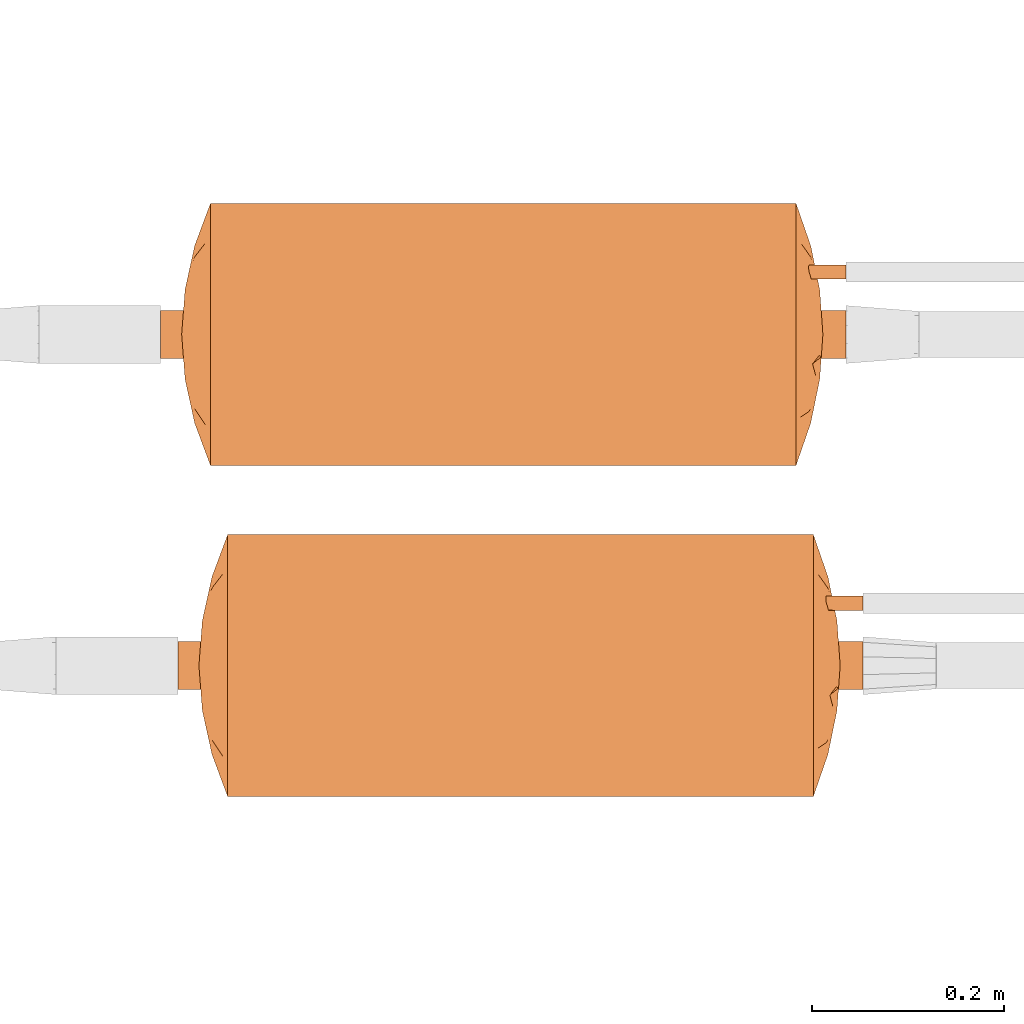
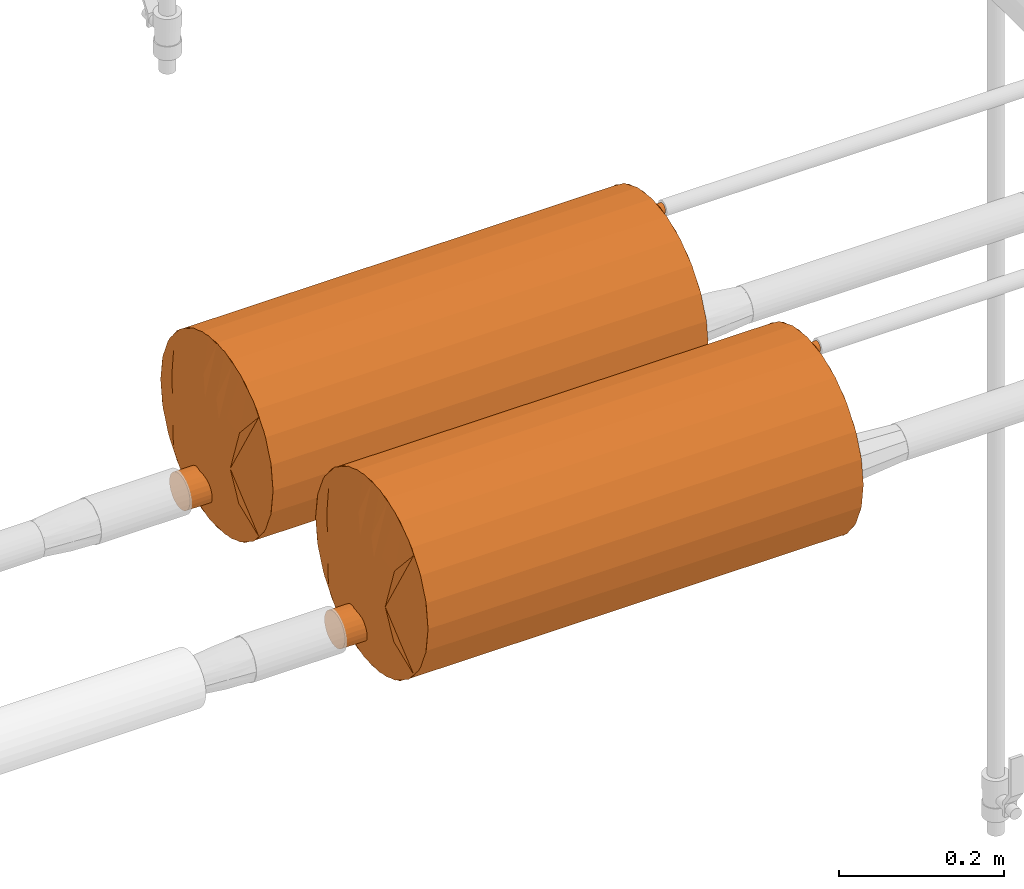
# One storey, part 825 of 827: 2 proxies.
"""IFC2X3 building model written with IfcOpenShell, lengths in millimetres."""

from ifc_helpers import new_model, entity, si_unit, converted_unit, derived_unit, direction, frame, origin, place, context, subcontext, project, spatial, faceted_brep, source, transform, mapped, material, material_list, type_object, type_shapes, element, save


model = new_model("IFC2X3")

# Units and contexts
model_context = context("Model", 3, precision=0.01, world=origin(), true_north=direction((6.12303176911189e-17, 1.0)))
body_context = subcontext(model_context, "Body", "Model", "MODEL_VIEW")
ifc_project = project(units=[si_unit("LENGTHUNIT", "METRE", prefix="MILLI"), si_unit("AREAUNIT", "SQUARE_METRE"), si_unit("VOLUMEUNIT", "CUBIC_METRE"), converted_unit("PLANEANGLEUNIT", "DEGREE", entity("IfcRatioMeasure", 0.0174532925199433), si_unit("PLANEANGLEUNIT", "RADIAN"), dimensions=[0, 0, 0, 0, 0, 0, 0]), si_unit("MASSUNIT", "GRAM", prefix="KILO"), derived_unit("MASSDENSITYUNIT", [(si_unit("MASSUNIT", "GRAM", prefix="KILO"), 1), (si_unit("LENGTHUNIT", "METRE"), -3)]), derived_unit("MOMENTOFINERTIAUNIT", [(si_unit("LENGTHUNIT", "METRE"), 4)]), si_unit("TIMEUNIT", "SECOND"), si_unit("FREQUENCYUNIT", "HERTZ"), si_unit("THERMODYNAMICTEMPERATUREUNIT", "DEGREE_CELSIUS"), derived_unit("THERMALTRANSMITTANCEUNIT", [(si_unit("MASSUNIT", "GRAM", prefix="KILO"), 1), (si_unit("THERMODYNAMICTEMPERATUREUNIT", "KELVIN"), -1), (si_unit("TIMEUNIT", "SECOND"), -3)]), derived_unit("VOLUMETRICFLOWRATEUNIT", [(si_unit("LENGTHUNIT", "METRE"), 3), (si_unit("TIMEUNIT", "SECOND"), -1)]), derived_unit("MASSFLOWRATEUNIT", [(si_unit("MASSUNIT", "GRAM", prefix="KILO"), 1), (si_unit("TIMEUNIT", "SECOND"), -1)]), derived_unit("ROTATIONALFREQUENCYUNIT", [(si_unit("TIMEUNIT", "SECOND"), -1)]), si_unit("ELECTRICCURRENTUNIT", "AMPERE"), si_unit("ELECTRICVOLTAGEUNIT", "VOLT"), si_unit("POWERUNIT", "WATT"), si_unit("FORCEUNIT", "NEWTON", prefix="KILO"), si_unit("ILLUMINANCEUNIT", "LUX"), si_unit("LUMINOUSFLUXUNIT", "LUMEN"), si_unit("LUMINOUSINTENSITYUNIT", "CANDELA"), derived_unit("USERDEFINED", [(si_unit("MASSUNIT", "GRAM", prefix="KILO"), -1), (si_unit("LENGTHUNIT", "METRE"), -2), (si_unit("TIMEUNIT", "SECOND"), 3), (si_unit("LUMINOUSFLUXUNIT", "LUMEN"), 1)]), derived_unit("LINEARVELOCITYUNIT", [(si_unit("LENGTHUNIT", "METRE"), 1), (si_unit("TIMEUNIT", "SECOND"), -1)]), si_unit("PRESSUREUNIT", "PASCAL"), derived_unit("USERDEFINED", [(si_unit("LENGTHUNIT", "METRE"), -2), (si_unit("MASSUNIT", "GRAM", prefix="KILO"), 1), (si_unit("TIMEUNIT", "SECOND"), -2)]), derived_unit("LINEARFORCEUNIT", [(si_unit("MASSUNIT", "GRAM", prefix="KILO"), 1), (si_unit("LENGTHUNIT", "METRE"), 1), (si_unit("TIMEUNIT", "SECOND"), -2), (si_unit("LENGTHUNIT", "METRE"), -1)]), derived_unit("PLANARFORCEUNIT", [(si_unit("MASSUNIT", "GRAM", prefix="KILO"), 1), (si_unit("LENGTHUNIT", "METRE"), 1), (si_unit("TIMEUNIT", "SECOND"), -2), (si_unit("LENGTHUNIT", "METRE"), -2)])], contexts=[model_context])

# Site, building, storey
site_placement = place(None, origin())
site = spatial("IfcSite", under=ifc_project, at=site_placement, CompositionType="ELEMENT")
building_placement = place(site_placement, origin())
building = spatial("IfcBuilding", under=site, at=building_placement, CompositionType="ELEMENT")
storey_placement = place(building_placement, frame((0.0, 0.0, 28200.0)))
storey = spatial("IfcBuildingStorey", under=building, at=storey_placement, Name="08", CompositionType="ELEMENT", Elevation=28200.0)

# Proxies
ifc_material_1 = material()
ifc_material_2 = material()
ifc_material_3 = material()
ifc_material_list = material_list([ifc_material_1, ifc_material_2, ifc_material_3])
building_element_proxy_type = type_object("IfcBuildingElementProxyType", Name=":Dy50", PredefinedType="NOTDEFINED", material=ifc_material_1)
shared_shape = source(origin(), body_context, "Body", "Brep", [
    faceted_brep([(68.75, -357.0, 58.5), (70.3, -357.0, 59.7), (71.5, -357.0, 61.25), (72.24, -357.0, 63.06), (72.5, -357.0, 65.0), (72.24, -357.0, 66.94), (71.5, -357.0, 68.75), (70.3, -357.0, 70.3), (68.75, -357.0, 71.5), (66.94, -357.0, 72.24), (65.0, -357.0, 72.5), (63.06, -357.0, 72.24), (61.25, -357.0, 71.5), (59.7, -357.0, 70.3), (58.5, -357.0, 68.75), (57.76, -357.0, 66.94), (57.5, -357.0, 65.0), (57.76, -357.0, 63.06), (58.5, -357.0, 61.25), (59.7, -357.0, 59.7), (61.25, -357.0, 58.5), (63.06, -357.0, 57.76), (65.0, -357.0, 57.5), (66.94, -357.0, 57.76), (65.0, 0.0, 72.5), (66.94, 0.0, 72.24), (68.75, 0.0, 71.5), (70.3, 0.0, 70.3), (71.5, 0.0, 68.75), (72.24, 0.0, 66.94), (72.5, 0.0, 65.0), (72.24, 0.0, 63.06), (71.5, 0.0, 61.25), (70.3, 0.0, 59.7), (68.75, 0.0, 58.5), (66.94, 0.0, 57.76), (65.0, 0.0, 57.5), (63.06, 0.0, 57.76), (61.25, 0.0, 58.5), (59.7, 0.0, 59.7), (58.5, 0.0, 61.25), (57.76, 0.0, 63.06), (57.5, 0.0, 65.0), (57.76, 0.0, 66.94), (58.5, 0.0, 68.75), (59.7, 0.0, 70.3), (61.25, 0.0, 71.5), (63.06, 0.0, 72.24), (65.0, -272.45, 57.5), (57.5, -261.38, 65.0), (57.5, -178.5, 65.0), (65.0, -130.69, 57.5), (57.5, -165.75, 65.0), (57.5, -95.62, 65.0), (72.5, -261.38, 65.0), (72.5, -165.75, 65.0), (72.5, -95.62, 65.0), (72.5, -178.5, 65.0), (65.0, -272.45, 72.5), (65.0, -130.69, 72.5)], [[[0, 1, 2, 3, 4, 5, 6, 7, 8, 9, 10, 11, 12, 13, 14, 15, 16, 17, 18, 19, 20, 21, 22, 23]], [[24, 25, 26, 27, 28, 29, 30, 31, 32, 33, 34, 35, 36, 37, 38, 39, 40, 41, 42, 43, 44, 45, 46, 47]], [[1, 0, 48]], [[48, 49, 50]], [[51, 50, 52, 53]], [[36, 51, 37]], [[21, 48, 22]], [[2, 1, 54]], [[37, 51, 38]], [[19, 18, 49]], [[53, 40, 39]], [[48, 51, 55]], [[38, 51, 53]], [[53, 42, 41]], [[17, 16, 49]], [[18, 17, 49]], [[50, 51, 48]], [[54, 4, 3]], [[31, 30, 56]], [[39, 38, 53]], [[54, 1, 48]], [[34, 51, 35]], [[40, 53, 41]], [[56, 51, 34]], [[33, 32, 56]], [[31, 56, 32]], [[35, 51, 36]], [[48, 23, 22]], [[51, 56, 55]], [[2, 54, 3]], [[48, 19, 49]], [[20, 48, 21]], [[48, 55, 57, 54]], [[19, 48, 20]], [[23, 48, 0]], [[34, 33, 56]], [[13, 12, 58]], [[24, 59, 25]], [[9, 58, 10]], [[14, 13, 49]], [[25, 59, 26]], [[56, 28, 27]], [[58, 59, 52]], [[58, 54, 57]], [[46, 59, 47]], [[26, 59, 56]], [[56, 30, 29]], [[5, 4, 54]], [[54, 7, 6]], [[54, 6, 5]], [[49, 16, 15]], [[43, 42, 53]], [[58, 57, 55, 56, 59]], [[49, 13, 58]], [[27, 26, 56]], [[53, 59, 46]], [[45, 44, 53]], [[53, 44, 43]], [[47, 59, 24]], [[11, 10, 58]], [[52, 59, 53]], [[14, 49, 15]], [[11, 58, 12]], [[58, 7, 54]], [[9, 8, 58]], [[58, 52, 50, 49]], [[7, 58, 8]], [[28, 56, 29]], [[46, 45, 53]]]),
    faceted_brep([(12.38, -357.0, -86.65), (17.56, -357.0, -82.68), (21.53, -357.0, -77.5), (24.03, -357.0, -71.47), (24.88, -357.0, -65.0), (24.03, -357.0, -58.53), (21.53, -357.0, -52.5), (17.56, -357.0, -47.32), (12.38, -357.0, -43.35), (6.35, -357.0, -40.85), (-0.12, -357.0, -40.0), (-6.59, -357.0, -40.85), (-12.62, -357.0, -43.35), (-17.79, -357.0, -47.32), (-21.77, -357.0, -52.5), (-24.27, -357.0, -58.53), (-25.12, -357.0, -65.0), (-24.27, -357.0, -71.47), (-21.77, -357.0, -77.5), (-17.79, -357.0, -82.68), (-12.62, -357.0, -86.65), (-6.59, -357.0, -89.15), (-0.12, -357.0, -90.0), (6.35, -357.0, -89.15), (17.56, 357.0, -47.32), (21.53, 357.0, -52.5), (24.03, 357.0, -58.53), (24.88, 357.0, -65.0), (24.03, 357.0, -71.47), (21.53, 357.0, -77.5), (17.56, 357.0, -82.68), (12.38, 357.0, -86.65), (6.35, 357.0, -89.15), (-0.12, 357.0, -90.0), (-6.59, 357.0, -89.15), (-12.62, 357.0, -86.65), (-17.79, 357.0, -82.68), (-21.77, 357.0, -77.5), (-24.27, 357.0, -71.47), (-25.12, 357.0, -65.0), (-24.27, 357.0, -58.53), (-21.77, 357.0, -52.5), (-17.79, 357.0, -47.32), (-12.62, 357.0, -43.35), (-6.59, 357.0, -40.85), (-0.12, 357.0, -40.0), (6.35, 357.0, -40.85), (12.38, 357.0, -43.35), (-23.21, 0.0, -74.57), (-9.68, 0.0, -88.1), (-3.38, -146.92, -89.79), (-15.34, -102.52, -84.83), (-19.95, -146.92, -80.22), (-19.95, 102.52, -80.22), (-15.34, 146.92, -84.83), (15.1, 102.52, -84.83), (19.72, 146.92, -80.22), (15.1, -146.92, -84.83), (19.72, -102.52, -80.22), (-3.38, 102.52, -89.79), (-24.64, 127.84, -69.88), (-25.12, 0.0, -65.0), (-24.64, -95.21, -69.88), (3.15, -102.52, -89.79), (3.15, 146.92, -89.79), (9.45, 0.0, -88.1), (22.98, 0.0, -74.57), (24.4, 95.21, -69.88), (24.88, 7.83, -65.0), (24.88, 0.0, -65.0), (24.88, -174.59, -65.0), (24.4, -127.84, -69.88), (15.1, -146.92, -45.17), (19.72, 0.0, -49.78), (22.98, 146.92, -55.43), (9.45, 0.0, -41.9), (15.1, 102.52, -45.17), (-15.34, 102.52, -45.17), (-19.95, 146.92, -49.78), (-15.34, -146.92, -45.17), (-19.95, -102.52, -49.78), (3.15, 102.52, -40.21), (24.42, -58.4, -60.19), (22.98, -102.52, -55.43), (24.51, 149.88, -60.72), (3.15, -146.92, -40.21), (-9.68, 0.0, -41.9), (-3.38, 146.92, -40.21), (-3.38, -102.52, -40.21), (-23.21, 0.0, -55.43), (-24.64, -127.84, -60.12), (-24.64, 95.21, -60.12)], [[[0, 1, 2, 3, 4, 5, 6, 7, 8, 9, 10, 11, 12, 13, 14, 15, 16, 17, 18, 19, 20, 21, 22, 23]], [[24, 25, 26, 27, 28, 29, 30, 31, 32, 33, 34, 35, 36, 37, 38, 39, 40, 41, 42, 43, 44, 45, 46, 47]], [[48, 38, 37]], [[49, 50, 21]], [[51, 52, 53, 54]], [[37, 53, 48]], [[49, 35, 34]], [[55, 30, 56]], [[57, 58, 1]], [[54, 49, 51]], [[48, 52, 18]], [[59, 49, 34]], [[38, 48, 60]], [[16, 61, 39, 60, 62]], [[38, 60, 39]], [[37, 36, 53]], [[51, 20, 19]], [[18, 17, 48]], [[63, 23, 22]], [[48, 53, 52]], [[20, 51, 49]], [[31, 30, 55]], [[21, 20, 49]], [[34, 33, 59]], [[49, 59, 50]], [[63, 50, 59, 64]], [[65, 32, 31]], [[59, 33, 64]], [[50, 63, 22]], [[31, 55, 65]], [[66, 29, 28]], [[30, 29, 56]], [[53, 36, 54]], [[56, 66, 58]], [[0, 57, 1]], [[67, 27, 68, 69, 70, 4, 71]], [[65, 23, 63]], [[0, 23, 65]], [[36, 35, 54]], [[58, 2, 1]], [[65, 55, 57]], [[21, 50, 22]], [[66, 2, 58]], [[2, 66, 3]], [[33, 32, 64]], [[66, 71, 3]], [[18, 52, 19]], [[52, 51, 19]], [[65, 63, 64]], [[71, 4, 3]], [[49, 54, 35]], [[65, 57, 0]], [[58, 57, 55, 56]], [[65, 64, 32]], [[66, 56, 29]], [[62, 60, 48]], [[48, 17, 62]], [[16, 62, 17]], [[67, 71, 66]], [[66, 28, 67]], [[27, 67, 28]], [[8, 7, 72]], [[73, 74, 25]], [[75, 72, 76]], [[24, 73, 25]], [[75, 47, 46]], [[77, 42, 78]], [[79, 80, 13]], [[73, 24, 76]], [[73, 72, 7]], [[81, 75, 46]], [[5, 70, 82]], [[25, 74, 26]], [[43, 42, 77]], [[24, 47, 76]], [[83, 6, 5]], [[6, 83, 73]], [[73, 83, 74]], [[73, 7, 6]], [[73, 76, 72]], [[46, 45, 81]], [[9, 8, 75]], [[84, 27, 26]], [[75, 81, 85]], [[82, 84, 74]], [[86, 44, 43]], [[81, 45, 87]], [[85, 88, 10]], [[43, 77, 86]], [[89, 41, 40]], [[42, 41, 78]], [[9, 85, 10]], [[78, 89, 80]], [[12, 79, 13]], [[39, 61, 16, 90, 91]], [[86, 11, 88]], [[12, 11, 86]], [[80, 14, 13]], [[90, 16, 15]], [[75, 8, 72]], [[86, 77, 79]], [[74, 84, 26]], [[89, 14, 80]], [[14, 89, 15]], [[68, 84, 82]], [[89, 90, 15]], [[47, 75, 76]], [[45, 44, 87]], [[86, 88, 87]], [[88, 11, 10]], [[75, 85, 9]], [[88, 85, 81, 87]], [[86, 79, 12]], [[80, 79, 77, 78]], [[86, 87, 44]], [[89, 78, 41]], [[82, 74, 83]], [[27, 84, 68]], [[83, 5, 82]], [[91, 90, 89]], [[70, 5, 4]], [[82, 70, 69, 68]], [[89, 40, 91]], [[39, 91, 40]]]),
    faceted_brep([(-117.43, -311.6, 0.0), (-122.2, -309.95, 0.0), (-126.96, -308.3, 0.0), (-136.5, -305.0, 0.0), (-134.31, -305.0, -15.22), (-133.48, -305.0, -21.03), (-132.64, -305.0, -26.84), (-130.97, -305.0, -38.46), (-104.89, -315.94, 0.0), (-111.16, -313.77, 0.0), (134.31, -305.0, -15.22), (136.5, -305.0, 0.0), (126.96, -308.3, 0.0), (122.2, -309.95, 0.0), (117.43, -311.6, 0.0), (111.16, -313.77, 0.0), (104.89, -315.94, 0.0), (130.97, -305.0, -38.46), (132.64, -305.0, -26.84), (133.48, -305.0, -21.03), (-92.36, -320.29, 0.0), (-122.9, -305.0, -56.13), (-80.92, -322.63, 0.0), (-114.83, -305.0, -73.8), (-102.11, -305.0, -88.48), (-89.39, -305.0, -103.16), (-80.85, -320.1, -46.02), (-22.64, -324.6, -71.44), (-23.3, -331.31, 0.0), (-43.31, -322.4, -72.3), (-73.91, -318.97, -62.88), (-73.05, -305.0, -113.66), (-62.62, -319.47, -71.82), (-34.95, -330.48, 0.0), (9.71, -325.72, -68.95), (30.69, -322.24, -79.19), (22.06, -328.95, -46.52), (80.17, -318.54, -57.22), (58.04, -327.32, 0.0), (69.66, -320.66, -58.5), (92.36, -320.29, 0.0), (122.9, -305.0, -56.13), (102.11, -305.0, -88.48), (80.92, -322.63, 0.0), (69.48, -324.97, 0.0), (42.94, -325.41, -56.7), (38.07, -305.0, -129.64), (56.7, -305.0, -124.16), (114.83, -305.0, -73.8), (55.82, -322.05, -64.98), (73.05, -305.0, -113.66), (-56.7, -305.0, -124.16), (19.43, -305.0, -135.11), (0.0, -305.0, -135.11), (-69.48, -324.97, 0.0), (89.39, -305.0, -103.16), (-58.04, -327.32, 0.0), (-46.6, -329.66, 0.0), (-38.07, -305.0, -129.64), (-19.43, -305.0, -135.11), (-4.27, -319.99, -93.34), (11.65, -332.14, 0.0), (0.0, -332.96, 0.0), (-5.95, -329.54, -47.08), (-11.65, -332.14, 0.0), (23.3, -331.31, 0.0), (46.6, -329.66, 0.0), (34.95, -330.48, 0.0), (134.31, -305.0, 15.22), (133.48, -305.0, 21.03), (132.64, -305.0, 26.84), (130.97, -305.0, 38.46), (-134.31, -305.0, 15.22), (-130.97, -305.0, 38.46), (-132.64, -305.0, 26.84), (-133.48, -305.0, 21.03), (122.9, -305.0, 56.13), (114.83, -305.0, 73.8), (102.11, -305.0, 88.48), (89.39, -305.0, 103.16), (80.85, -320.1, 46.02), (22.64, -324.6, 71.44), (43.31, -322.4, 72.3), (73.91, -318.97, 62.88), (73.05, -305.0, 113.66), (62.62, -319.47, 71.82), (56.7, -305.0, 124.16), (-9.71, -325.72, 68.95), (-30.69, -322.24, 79.19), (-22.06, -328.95, 46.52), (-80.17, -318.54, 57.22), (-69.66, -320.66, 58.5), (-122.9, -305.0, 56.13), (-102.11, -305.0, 88.48), (-114.83, -305.0, 73.8), (-42.94, -325.41, 56.7), (-38.07, -305.0, 129.64), (-56.7, -305.0, 124.16), (-55.82, -322.05, 64.98), (-73.05, -305.0, 113.66), (-19.43, -305.0, 135.11), (0.0, -305.0, 135.11), (-89.39, -305.0, 103.16), (38.07, -305.0, 129.64), (19.43, -305.0, 135.11), (4.27, -319.99, 93.34), (5.95, -329.54, 47.08), (0.0, -305.0, 0.0)], [[[0, 1, 2, 3, 4, 5, 6, 7, 8, 9]], [[10, 11, 12, 13, 14, 15, 16, 17, 18, 19]], [[20, 8, 21]], [[22, 23, 24]], [[24, 25, 26]], [[27, 28, 29]], [[30, 25, 31]], [[32, 29, 33]], [[34, 35, 36]], [[37, 38, 39]], [[40, 41, 16]], [[42, 43, 44]], [[20, 21, 23]], [[45, 46, 47]], [[41, 40, 48]], [[49, 50, 39]], [[32, 51, 29]], [[16, 41, 17]], [[52, 34, 53]], [[8, 7, 21]], [[48, 40, 43]], [[24, 54, 22]], [[22, 20, 23]], [[44, 55, 42]], [[48, 43, 42]], [[31, 32, 30]], [[29, 28, 33]], [[34, 52, 35]], [[31, 51, 32]], [[30, 56, 26]], [[30, 57, 56]], [[27, 58, 59]], [[58, 27, 29]], [[59, 53, 60]], [[36, 61, 34]], [[62, 63, 34]], [[63, 60, 34]], [[64, 27, 63]], [[57, 30, 32]], [[56, 54, 26]], [[24, 26, 54]], [[25, 30, 26]], [[45, 47, 49]], [[57, 32, 33]], [[45, 65, 35]], [[35, 52, 46]], [[66, 67, 49]], [[49, 47, 50]], [[44, 38, 37]], [[49, 39, 66]], [[66, 39, 38]], [[37, 50, 55]], [[45, 49, 67]], [[50, 37, 39]], [[44, 37, 55]], [[29, 51, 58]], [[63, 62, 64]], [[64, 28, 27]], [[34, 60, 53]], [[63, 27, 60]], [[59, 60, 27]], [[65, 45, 67]], [[46, 45, 35]], [[36, 65, 61]], [[61, 62, 34]], [[65, 36, 35]], [[14, 13, 12, 11, 68, 69, 70, 71, 16, 15]], [[72, 3, 2, 1, 0, 9, 8, 73, 74, 75]], [[40, 16, 76]], [[43, 77, 78]], [[78, 79, 80]], [[81, 65, 82]], [[83, 79, 84]], [[85, 82, 67]], [[85, 86, 82]], [[87, 88, 89]], [[90, 56, 91]], [[20, 92, 8]], [[93, 22, 54]], [[94, 20, 22]], [[95, 96, 97]], [[92, 20, 94]], [[98, 99, 91]], [[8, 92, 73]], [[40, 76, 77]], [[100, 87, 101]], [[16, 71, 76]], [[78, 44, 43]], [[43, 40, 77]], [[54, 102, 93]], [[94, 22, 93]], [[84, 85, 83]], [[82, 65, 67]], [[87, 100, 88]], [[84, 86, 85]], [[83, 38, 80]], [[83, 66, 38]], [[81, 103, 104]], [[103, 81, 82]], [[104, 101, 105]], [[89, 64, 87]], [[62, 106, 87]], [[106, 105, 87]], [[61, 81, 106]], [[66, 83, 85]], [[38, 44, 80]], [[78, 80, 44]], [[79, 83, 80]], [[95, 97, 98]], [[66, 85, 67]], [[95, 28, 88]], [[88, 100, 96]], [[57, 33, 98]], [[98, 97, 99]], [[54, 56, 90]], [[98, 91, 57]], [[57, 91, 56]], [[90, 99, 102]], [[95, 98, 33]], [[99, 90, 91]], [[54, 90, 102]], [[82, 86, 103]], [[106, 62, 61]], [[61, 65, 81]], [[87, 105, 101]], [[106, 81, 105]], [[104, 105, 81]], [[28, 95, 33]], [[96, 95, 88]], [[89, 28, 64]], [[64, 62, 87]], [[28, 89, 88]], [[107, 48, 42]], [[107, 42, 55]], [[107, 55, 50]], [[107, 41, 48]], [[107, 17, 41]], [[107, 50, 47]], [[107, 47, 46]], [[107, 46, 52]], [[107, 52, 53]], [[107, 18, 17]], [[107, 19, 18]], [[107, 10, 19]], [[107, 11, 10]], [[107, 53, 59]], [[107, 59, 58]], [[107, 58, 51]], [[107, 51, 31]], [[107, 31, 25]], [[107, 25, 24]], [[107, 24, 23]], [[107, 23, 21]], [[107, 21, 7]], [[107, 7, 6]], [[107, 6, 5]], [[107, 5, 4]], [[107, 4, 3]], [[107, 3, 72]], [[107, 68, 11]], [[107, 69, 68]], [[107, 70, 69]], [[107, 71, 70]], [[107, 76, 71]], [[107, 77, 76]], [[107, 78, 77]], [[107, 79, 78]], [[107, 84, 79]], [[107, 86, 84]], [[107, 103, 86]], [[107, 104, 103]], [[107, 72, 75]], [[107, 75, 74]], [[107, 74, 73]], [[107, 73, 92]], [[107, 92, 94]], [[107, 94, 93]], [[107, 93, 102]], [[107, 102, 99]], [[107, 99, 97]], [[107, 97, 96]], [[107, 96, 100]], [[107, 100, 101]], [[107, 101, 104]]]),
    faceted_brep([(-62.63, 320.56, -71.87), (-56.7, 305.0, -124.16), (-73.05, 305.0, -113.66), (132.71, 305.0, -26.35), (130.97, 305.0, -38.46), (105.61, 316.52, 0.0), (112.13, 314.09, 0.0), (118.65, 311.66, 0.0), (127.58, 308.33, 0.0), (136.5, 305.0, 0.0), (134.45, 305.0, -14.25), (-130.97, 305.0, -38.46), (-132.71, 305.0, -26.35), (-134.45, 305.0, -14.25), (-136.5, 305.0, 0.0), (-127.58, 308.33, 0.0), (-118.65, 311.66, 0.0), (-112.13, 314.09, 0.0), (-105.61, 316.52, 0.0), (-43.29, 323.62, -72.72), (-35.07, 332.34, 0.0), (-74.01, 320.0, -62.95), (-46.76, 331.45, 0.0), (80.37, 319.55, -57.09), (73.05, 305.0, -113.66), (69.89, 321.78, -58.62), (-114.83, 305.0, -73.8), (-122.9, 305.0, -56.13), (-92.56, 321.39, 0.0), (-69.66, 326.42, 0.0), (-102.11, 305.0, -88.48), (-81.11, 323.9, 0.0), (92.56, 321.39, 0.0), (122.9, 305.0, -56.13), (114.83, 305.0, -73.8), (-81.18, 321.08, -46.58), (19.43, 305.0, -135.11), (9.71, 327.22, -69.16), (30.77, 323.48, -79.4), (102.11, 305.0, -88.48), (89.39, 305.0, -103.16), (24.07, 331.23, -41.83), (11.69, 334.11, 0.0), (56.04, 323.27, -65.12), (56.7, 305.0, -124.16), (81.11, 323.9, 0.0), (0.0, 305.0, -135.11), (69.66, 326.42, 0.0), (-58.21, 328.94, 0.0), (-22.47, 326.09, -71.38), (-23.38, 333.23, 0.0), (-11.69, 334.11, 0.0), (46.76, 331.45, 0.0), (35.07, 332.34, 0.0), (-38.07, 305.0, -129.64), (23.38, 333.23, 0.0), (-4.32, 321.07, -93.54), (-19.43, 305.0, -135.11), (0.0, 335.0, 0.0), (-5.98, 331.33, -47.21), (-89.39, 305.0, -103.16), (43.09, 326.88, -56.92), (38.07, 305.0, -129.64), (58.21, 328.94, 0.0), (62.63, 320.56, 71.87), (56.7, 305.0, 124.16), (73.05, 305.0, 113.66), (-132.71, 305.0, 26.35), (-130.97, 305.0, 38.46), (-134.45, 305.0, 14.25), (130.97, 305.0, 38.46), (132.71, 305.0, 26.35), (134.45, 305.0, 14.25), (43.29, 323.62, 72.72), (74.01, 320.0, 62.95), (114.83, 305.0, 73.8), (122.9, 305.0, 56.13), (-80.37, 319.55, 57.09), (-73.05, 305.0, 113.66), (-69.89, 321.78, 58.62), (102.11, 305.0, 88.48), (81.18, 321.08, 46.58), (-19.43, 305.0, 135.11), (-9.71, 327.22, 69.16), (-30.77, 323.48, 79.4), (-102.11, 305.0, 88.48), (-89.39, 305.0, 103.16), (-24.07, 331.23, 41.83), (-114.83, 305.0, 73.8), (-56.04, 323.27, 65.12), (-56.7, 305.0, 124.16), (-122.9, 305.0, 56.13), (0.0, 305.0, 135.11), (22.47, 326.09, 71.38), (38.07, 305.0, 129.64), (4.32, 321.07, 93.54), (19.43, 305.0, 135.11), (5.98, 331.33, 47.21), (89.39, 305.0, 103.16), (-43.09, 326.88, 56.92), (-38.07, 305.0, 129.64), (0.0, 305.0, 0.0)], [[[0, 1, 2]], [[3, 4, 5, 6, 7, 8, 9, 10]], [[11, 12, 13, 14, 15, 16, 17, 18]], [[0, 19, 1]], [[0, 20, 19]], [[0, 21, 22]], [[23, 24, 25]], [[26, 27, 28]], [[11, 18, 27]], [[29, 30, 31]], [[32, 33, 34]], [[35, 30, 29]], [[36, 37, 38]], [[39, 40, 23]], [[32, 5, 33]], [[41, 37, 42]], [[26, 28, 31]], [[43, 24, 44]], [[5, 4, 33]], [[45, 34, 39]], [[28, 27, 18]], [[36, 46, 37]], [[26, 31, 30]], [[39, 47, 45]], [[45, 32, 34]], [[48, 21, 35]], [[49, 50, 51]], [[52, 43, 53]], [[21, 0, 2]], [[35, 29, 48]], [[20, 0, 22]], [[49, 19, 50]], [[49, 54, 19]], [[42, 55, 41]], [[56, 57, 49]], [[58, 59, 51]], [[37, 56, 59]], [[59, 58, 37]], [[60, 21, 2]], [[22, 21, 48]], [[21, 60, 35]], [[30, 35, 60]], [[55, 53, 61]], [[50, 19, 20]], [[62, 38, 61]], [[52, 25, 43]], [[43, 61, 53]], [[62, 61, 44]], [[63, 25, 52]], [[23, 25, 63]], [[23, 47, 39]], [[43, 25, 24]], [[38, 62, 36]], [[47, 23, 63]], [[24, 23, 40]], [[54, 49, 57]], [[54, 1, 19]], [[56, 37, 46]], [[49, 51, 59]], [[57, 56, 46]], [[49, 59, 56]], [[61, 43, 44]], [[61, 38, 41]], [[37, 58, 42]], [[61, 41, 55]], [[37, 41, 38]], [[64, 65, 66]], [[67, 68, 18, 17, 16, 15, 14, 69]], [[70, 71, 72, 9, 8, 7, 6, 5]], [[64, 73, 65]], [[64, 53, 73]], [[64, 74, 52]], [[75, 76, 32]], [[77, 78, 79]], [[70, 5, 76]], [[47, 80, 45]], [[75, 32, 45]], [[81, 80, 47]], [[82, 83, 84]], [[85, 86, 77]], [[87, 83, 51]], [[31, 88, 85]], [[89, 78, 90]], [[32, 76, 5]], [[18, 91, 28]], [[18, 68, 91]], [[82, 92, 83]], [[28, 91, 88]], [[75, 45, 80]], [[85, 29, 31]], [[31, 28, 88]], [[63, 74, 81]], [[93, 55, 42]], [[22, 89, 20]], [[74, 64, 66]], [[81, 47, 63]], [[53, 64, 52]], [[93, 73, 55]], [[93, 94, 73]], [[51, 50, 87]], [[95, 96, 93]], [[58, 97, 42]], [[83, 95, 97]], [[97, 58, 83]], [[98, 74, 66]], [[52, 74, 63]], [[74, 98, 81]], [[80, 81, 98]], [[50, 20, 99]], [[55, 73, 53]], [[100, 84, 99]], [[22, 79, 89]], [[89, 99, 20]], [[100, 99, 90]], [[48, 79, 22]], [[77, 79, 48]], [[77, 29, 85]], [[89, 79, 78]], [[84, 100, 82]], [[29, 77, 48]], [[78, 77, 86]], [[94, 93, 96]], [[94, 65, 73]], [[95, 83, 92]], [[93, 42, 97]], [[96, 95, 92]], [[93, 97, 95]], [[99, 89, 90]], [[99, 84, 87]], [[83, 58, 51]], [[99, 87, 50]], [[83, 87, 84]], [[101, 40, 39]], [[101, 39, 34]], [[101, 34, 33]], [[101, 33, 4]], [[101, 4, 3]], [[101, 24, 40]], [[101, 44, 24]], [[101, 62, 44]], [[101, 36, 62]], [[101, 3, 10]], [[101, 10, 9]], [[101, 9, 72]], [[101, 46, 36]], [[101, 57, 46]], [[101, 54, 57]], [[101, 1, 54]], [[101, 2, 1]], [[101, 60, 2]], [[101, 30, 60]], [[101, 26, 30]], [[101, 27, 26]], [[101, 11, 27]], [[101, 12, 11]], [[101, 13, 12]], [[101, 14, 13]], [[101, 72, 71]], [[101, 71, 70]], [[101, 70, 76]], [[101, 76, 75]], [[101, 75, 80]], [[101, 80, 98]], [[101, 98, 66]], [[101, 66, 65]], [[101, 65, 94]], [[101, 94, 96]], [[101, 96, 92]], [[101, 69, 14]], [[101, 67, 69]], [[101, 68, 67]], [[101, 91, 68]], [[101, 88, 91]], [[101, 85, 88]], [[101, 86, 85]], [[101, 78, 86]], [[101, 90, 78]], [[101, 100, 90]], [[101, 82, 100]], [[101, 92, 82]]]),
    faceted_brep([(35.33, -305.0, -131.85), (68.25, -305.0, -118.21), (96.52, -305.0, -96.52), (118.21, -305.0, -68.25), (131.85, -305.0, -35.33), (136.5, -305.0, 0.0), (131.85, -305.0, 35.33), (118.21, -305.0, 68.25), (96.52, -305.0, 96.52), (68.25, -305.0, 118.21), (35.33, -305.0, 131.85), (0.0, -305.0, 136.5), (-35.33, -305.0, 131.85), (-68.25, -305.0, 118.21), (-96.52, -305.0, 96.52), (-118.21, -305.0, 68.25), (-131.85, -305.0, 35.33), (-136.5, -305.0, 0.0), (-131.85, -305.0, -35.33), (-118.21, -305.0, -68.25), (-96.52, -305.0, -96.52), (-68.25, -305.0, -118.21), (-35.33, -305.0, -131.85), (0.0, -305.0, -136.5), (35.33, 305.0, 131.85), (68.25, 305.0, 118.21), (96.52, 305.0, 96.52), (118.21, 305.0, 68.25), (131.85, 305.0, 35.33), (136.5, 305.0, 0.0), (131.85, 305.0, -35.33), (118.21, 305.0, -68.25), (96.52, 305.0, -96.52), (68.25, 305.0, -118.21), (35.33, 305.0, -131.85), (0.0, 305.0, -136.5), (-35.33, 305.0, -131.85), (-68.25, 305.0, -118.21), (-96.52, 305.0, -96.52), (-118.21, 305.0, -68.25), (-131.85, 305.0, -35.33), (-136.5, 305.0, 0.0), (-131.85, 305.0, 35.33), (-118.21, 305.0, 68.25), (-96.52, 305.0, 96.52), (-68.25, 305.0, 118.21), (-35.33, 305.0, 131.85), (0.0, 305.0, 136.5)], [[[0, 1, 2, 3, 4, 5, 6, 7, 8, 9, 10, 11, 12, 13, 14, 15, 16, 17, 18, 19, 20, 21, 22, 23]], [[24, 25, 26, 27, 28, 29, 30, 31, 32, 33, 34, 35, 36, 37, 38, 39, 40, 41, 42, 43, 44, 45, 46, 47]], [[18, 40, 39, 19]], [[38, 20, 19, 39]], [[21, 37, 36, 22]], [[38, 37, 21, 20]], [[22, 36, 35, 23]], [[40, 18, 17, 41]], [[0, 34, 33, 1]], [[32, 2, 1, 33]], [[3, 31, 30, 4]], [[32, 31, 3, 2]], [[4, 30, 29, 5]], [[34, 0, 23, 35]], [[7, 27, 26, 8]], [[9, 25, 24, 10]], [[26, 25, 9, 8]], [[47, 11, 10, 24]], [[5, 29, 28, 6]], [[28, 27, 7, 6]], [[12, 46, 45, 13]], [[44, 14, 13, 45]], [[15, 43, 42, 16]], [[44, 43, 15, 14]], [[16, 42, 41, 17]], [[46, 12, 11, 47]]]),
])
type_shapes(building_element_proxy_type, [shared_shape])
for number, where, z_axis, x_axis, name in (
    (1, (24899.69, 14505.6, 3063.24), (0.0, 0.0, 1.0), (0.0, 1.0, 0.0), ":Dy50"),
    (2, (24881.71, 14850.58, 3065.0), (0.0, 0.0, 1.0), (0.0, 1.0, 0.0), ":Dy50"),
):
    element("IfcBuildingElementProxy", number, at=place(storey_placement, frame(where, z_axis=z_axis, x_axis=x_axis)), inside=storey, type_object=building_element_proxy_type, material=ifc_material_list, Name=name, ObjectType=":Dy50", context=body_context, shape_type="MappedRepresentation", body=[
        mapped(shared_shape, transform((0.0, 0.0, 0.0), scale=1.0)),
    ])

save(model, "model.ifc")
